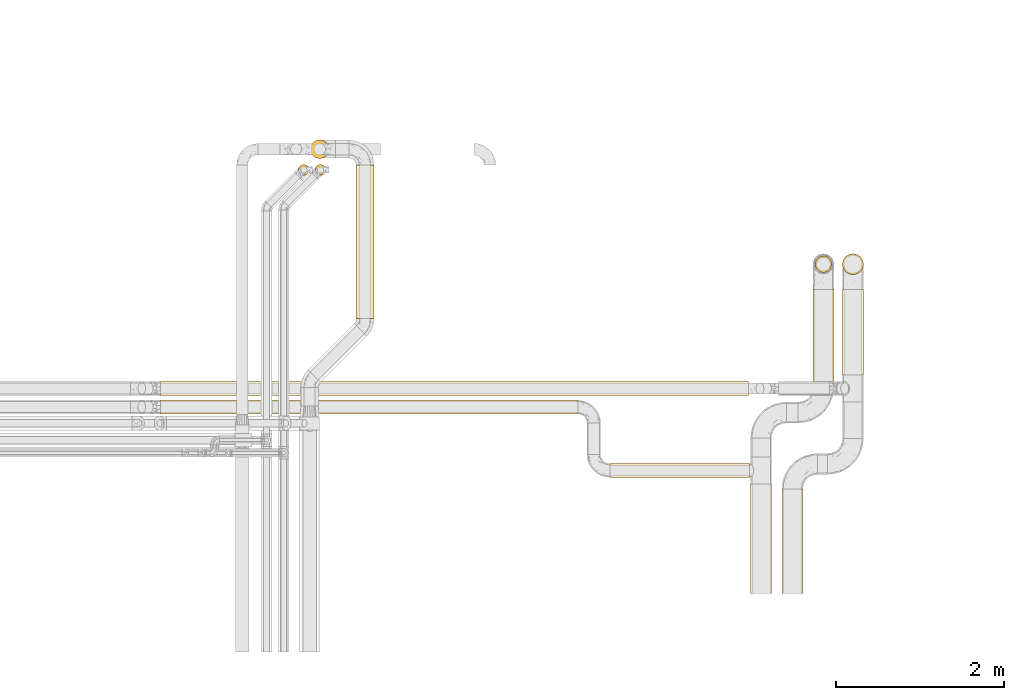
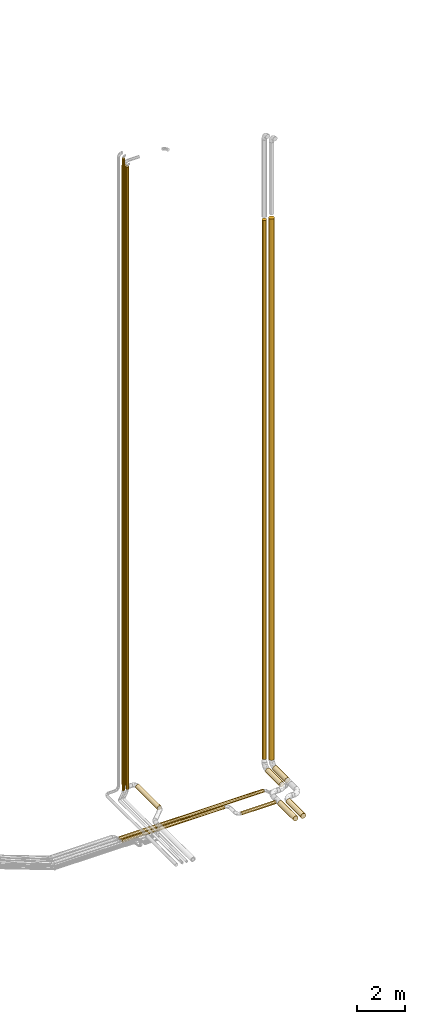
# One storey, part 2 of 93: 13 coverings.
"""IFC2X3 building model written with IfcOpenShell, lengths in millimetres."""

from ifc_helpers import new_model, entity, si_unit, converted_unit, derived_unit, direction, frame, origin, origin_2d_with_axis, place, context, subcontext, project, spatial, circle, extrude, element, save


model = new_model("IFC2X3")

# Units and contexts
model_context = context("Model", 3, precision=0.01, world=origin(), true_north=direction((6.12303176911189e-17, 1.0)))
body_context = subcontext(model_context, "Body", "Model", "MODEL_VIEW")
ifc_project = project(units=[si_unit("LENGTHUNIT", "METRE", prefix="MILLI"), si_unit("AREAUNIT", "SQUARE_METRE"), si_unit("VOLUMEUNIT", "CUBIC_METRE"), converted_unit("PLANEANGLEUNIT", "DEGREE", entity("IfcRatioMeasure", 0.0174532925199433), si_unit("PLANEANGLEUNIT", "RADIAN"), dimensions=[0, 0, 0, 0, 0, 0, 0]), si_unit("MASSUNIT", "GRAM", prefix="KILO"), derived_unit("MASSDENSITYUNIT", [(si_unit("MASSUNIT", "GRAM", prefix="KILO"), 1), (si_unit("LENGTHUNIT", "METRE"), -3)]), derived_unit("MOMENTOFINERTIAUNIT", [(si_unit("LENGTHUNIT", "METRE"), 4)]), si_unit("TIMEUNIT", "SECOND"), si_unit("FREQUENCYUNIT", "HERTZ"), si_unit("THERMODYNAMICTEMPERATUREUNIT", "DEGREE_CELSIUS"), derived_unit("THERMALTRANSMITTANCEUNIT", [(si_unit("MASSUNIT", "GRAM", prefix="KILO"), 1), (si_unit("THERMODYNAMICTEMPERATUREUNIT", "KELVIN"), -1), (si_unit("TIMEUNIT", "SECOND"), -3)]), derived_unit("VOLUMETRICFLOWRATEUNIT", [(si_unit("LENGTHUNIT", "METRE"), 3), (si_unit("TIMEUNIT", "SECOND"), -1)]), derived_unit("MASSFLOWRATEUNIT", [(si_unit("MASSUNIT", "GRAM", prefix="KILO"), 1), (si_unit("TIMEUNIT", "SECOND"), -1)]), derived_unit("ROTATIONALFREQUENCYUNIT", [(si_unit("TIMEUNIT", "SECOND"), -1)]), si_unit("ELECTRICCURRENTUNIT", "AMPERE"), si_unit("ELECTRICVOLTAGEUNIT", "VOLT"), si_unit("POWERUNIT", "WATT"), si_unit("FORCEUNIT", "NEWTON", prefix="KILO"), si_unit("ILLUMINANCEUNIT", "LUX"), si_unit("LUMINOUSFLUXUNIT", "LUMEN"), si_unit("LUMINOUSINTENSITYUNIT", "CANDELA"), derived_unit("USERDEFINED", [(si_unit("MASSUNIT", "GRAM", prefix="KILO"), -1), (si_unit("LENGTHUNIT", "METRE"), -2), (si_unit("TIMEUNIT", "SECOND"), 3), (si_unit("LUMINOUSFLUXUNIT", "LUMEN"), 1)]), derived_unit("LINEARVELOCITYUNIT", [(si_unit("LENGTHUNIT", "METRE"), 1), (si_unit("TIMEUNIT", "SECOND"), -1)]), si_unit("PRESSUREUNIT", "PASCAL"), derived_unit("USERDEFINED", [(si_unit("LENGTHUNIT", "METRE"), -2), (si_unit("MASSUNIT", "GRAM", prefix="KILO"), 1), (si_unit("TIMEUNIT", "SECOND"), -2)]), derived_unit("LINEARFORCEUNIT", [(si_unit("MASSUNIT", "GRAM", prefix="KILO"), 1), (si_unit("LENGTHUNIT", "METRE"), 1), (si_unit("TIMEUNIT", "SECOND"), -2), (si_unit("LENGTHUNIT", "METRE"), -1)]), derived_unit("PLANARFORCEUNIT", [(si_unit("MASSUNIT", "GRAM", prefix="KILO"), 1), (si_unit("LENGTHUNIT", "METRE"), 1), (si_unit("TIMEUNIT", "SECOND"), -2), (si_unit("LENGTHUNIT", "METRE"), -2)])], contexts=[model_context])

# Site, building, storey
site_placement = place(None, origin())
site = spatial("IfcSite", under=ifc_project, at=site_placement, CompositionType="ELEMENT")
building_placement = place(site_placement, origin())
building = spatial("IfcBuilding", under=site, at=building_placement, CompositionType="ELEMENT")
storey_placement = place(building_placement, frame((0.0, 0.0, -4200.0)))
storey = spatial("IfcBuildingStorey", under=building, at=storey_placement, CompositionType="ELEMENT", Elevation=-4200.0)

# Coverings
covering_1_placement = place(storey_placement, frame((25531.03, 10304.27, 2891.9)))
element("IfcCovering", 1, at=covering_1_placement, inside=storey, Name=":ADSK_", ObjectType=":ADSK_", PredefinedType="INSULATION", context=body_context, shape_type="SweptSolid", body=[
    extrude(circle(Radius=106.5, at=origin_2d_with_axis()), frame((108.1, 0.0, 108.1), z_axis=(0.0, 1.0, 0.0), x_axis=(-1.0, 0.0, 0.0)), (0.0, 0.0, 1.0), 1821.29942314912),
])
covering_2_placement = place(storey_placement, frame((24987.53, 12203.97, 3190.0)))
element("IfcCovering", 2, at=covering_2_placement, inside=storey, Name=":ADSK_", ObjectType=":ADSK_", PredefinedType="INSULATION", context=body_context, shape_type="SweptSolid", body=[
    extrude(circle(Radius=110.0, at=origin_2d_with_axis()), frame((111.6, 111.6, 0.0)), (0.0, 0.0, 1.0), 31620.0),
])
covering_3_placement = place(storey_placement, frame((30213.69, 7038.76, 2673.9)))
element("IfcCovering", 3, at=covering_3_placement, inside=storey, Name=":ADSK_", ObjectType=":ADSK_", PredefinedType="INSULATION", context=body_context, shape_type="SweptSolid", body=[
    extrude(circle(Radius=124.5, at=origin_2d_with_axis()), frame((126.1, 0.0, 126.1), z_axis=(0.0, 1.0, 0.0), x_axis=(-1.0, 0.0, 0.0)), (0.0, 0.0, 1.0), 1301.23958365229),
])
covering_4_placement = place(storey_placement, frame((30980.9, 10850.9, 3240.0)))
element("IfcCovering", 4, at=covering_4_placement, inside=storey, Name=":ADSK_", ObjectType=":ADSK_", PredefinedType="INSULATION", context=body_context, shape_type="SweptSolid", body=[
    extrude(circle(Radius=97.5, at=origin_2d_with_axis()), frame((99.1, 99.1, 0.0), z_axis=(0.0, 0.0, 1.0), x_axis=(-1.0, 0.0, 0.0)), (0.0, 0.0, 1.0), 27542.5),
])
covering_5_placement = place(storey_placement, frame((24847.71, 12005.41, 3100.0)))
element("IfcCovering", 5, at=covering_5_placement, inside=storey, Name=":ADSK_", ObjectType=":ADSK_", PredefinedType="INSULATION", context=body_context, shape_type="SweptSolid", body=[
    extrude(circle(Radius=63.0, at=origin_2d_with_axis()), frame((64.6, 64.6, 0.0), z_axis=(0.0, 0.0, 1.0), x_axis=(-1.0, 0.0, 0.0)), (0.0, 0.0, 1.0), 32300.0),
])
covering_6_placement = place(storey_placement, frame((25044.13, 12005.41, 3100.0)))
element("IfcCovering", 6, at=covering_6_placement, inside=storey, Name=":ADSK_", ObjectType=":ADSK_", PredefinedType="INSULATION", context=body_context, shape_type="SweptSolid", body=[
    extrude(circle(Radius=63.0, at=origin_2d_with_axis()), frame((64.6, 64.6, 0.0), z_axis=(0.0, 0.0, 1.0), x_axis=(-1.0, 0.0, 0.0)), (0.0, 0.0, 1.0), 31800.0),
])
covering_7_placement = place(storey_placement, frame((30583.69, 7038.76, 2673.9)))
element("IfcCovering", 7, at=covering_7_placement, inside=storey, Name=":ADSK_", ObjectType=":ADSK_", PredefinedType="INSULATION", context=body_context, shape_type="SweptSolid", body=[
    extrude(circle(Radius=124.5, at=origin_2d_with_axis()), frame((126.1, 0.0, 126.1), z_axis=(0.0, 1.0, 0.0), x_axis=(-1.0, 0.0, 0.0)), (0.0, 0.0, 1.0), 1239.99999999999),
])
covering_8_placement = place(storey_placement, frame((31303.9, 9634.14, 2673.9)))
element("IfcCovering", 8, at=covering_8_placement, inside=storey, Name=":ADSK_", ObjectType=":ADSK_", PredefinedType="INSULATION", context=body_context, shape_type="SweptSolid", body=[
    extrude(circle(Radius=124.5, at=origin_2d_with_axis()), frame((126.1, 0.0, 126.1), z_axis=(0.0, 1.0, 0.0), x_axis=(0.707106781186549, 0.0, -0.707106781186546)), (0.0, 0.0, 1.0), 1015.8612780823),
])
covering_9_placement = place(storey_placement, frame((31303.9, 10823.9, 3100.0)))
element("IfcCovering", 9, at=covering_9_placement, inside=storey, Name=":ADSK_", ObjectType=":ADSK_", PredefinedType="INSULATION", context=body_context, shape_type="SweptSolid", body=[
    extrude(circle(Radius=124.5, at=origin_2d_with_axis()), frame((126.1, 126.1, 0.0)), (0.0, 0.0, 1.0), 27657.5),
])
covering_10_placement = place(storey_placement, frame((23210.57, 9391.04, 2716.9)))
element("IfcCovering", 10, at=covering_10_placement, inside=storey, Name=":ADSK_", ObjectType=":ADSK_", PredefinedType="INSULATION", context=body_context, shape_type="SweptSolid", body=[
    extrude(circle(Radius=81.5, at=origin_2d_with_axis()), frame((0.0, 83.1, 83.1), z_axis=(1.0, 0.0, 0.0), x_axis=(0.0, 1.0, 0.0)), (0.0, 0.0, 1.0), 6980.73067498007),
])
covering_11_placement = place(storey_placement, frame((23210.57, 9171.64, 2716.9)))
element("IfcCovering", 11, at=covering_11_placement, inside=storey, Name=":ADSK_", ObjectType=":ADSK_", PredefinedType="INSULATION", context=body_context, shape_type="SweptSolid", body=[
    extrude(circle(Radius=81.5, at=origin_2d_with_axis()), frame((0.0, 83.1, 83.1), z_axis=(1.0, 0.0, 0.0), x_axis=(0.0, -1.0, 0.0)), (0.0, 0.0, 1.0), 4952.83139254912),
])
covering_12_placement = place(storey_placement, frame((28543.4, 8416.9, 2716.9)))
element("IfcCovering", 12, at=covering_12_placement, inside=storey, Name=":ADSK_", ObjectType=":ADSK_", PredefinedType="INSULATION", context=body_context, shape_type="SweptSolid", body=[
    extrude(circle(Radius=81.5, at=origin_2d_with_axis()), frame((0.0, 83.1, 83.1), z_axis=(1.0, 0.0, 0.0), x_axis=(0.0, 1.0, 0.0)), (0.0, 0.0, 1.0), 1656.38155763209),
])
covering_13_placement = place(storey_placement, frame((30953.9, 9488.76, 2673.9)))
element("IfcCovering", 13, at=covering_13_placement, inside=storey, Name=":ADSK_", ObjectType=":ADSK_", PredefinedType="INSULATION", context=body_context, shape_type="SweptSolid", body=[
    extrude(circle(Radius=124.5, at=origin_2d_with_axis()), frame((126.1, 0.0, 126.1), z_axis=(0.0, 1.0, 0.0), x_axis=(-1.0, 0.0, 0.0)), (0.0, 0.0, 1.0), 1161.23991781962),
])

save(model, "model.ifc")
